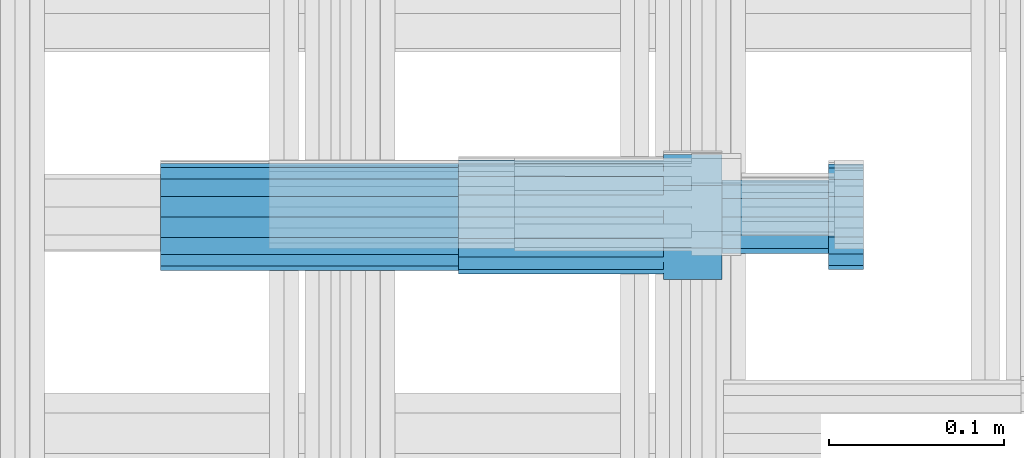
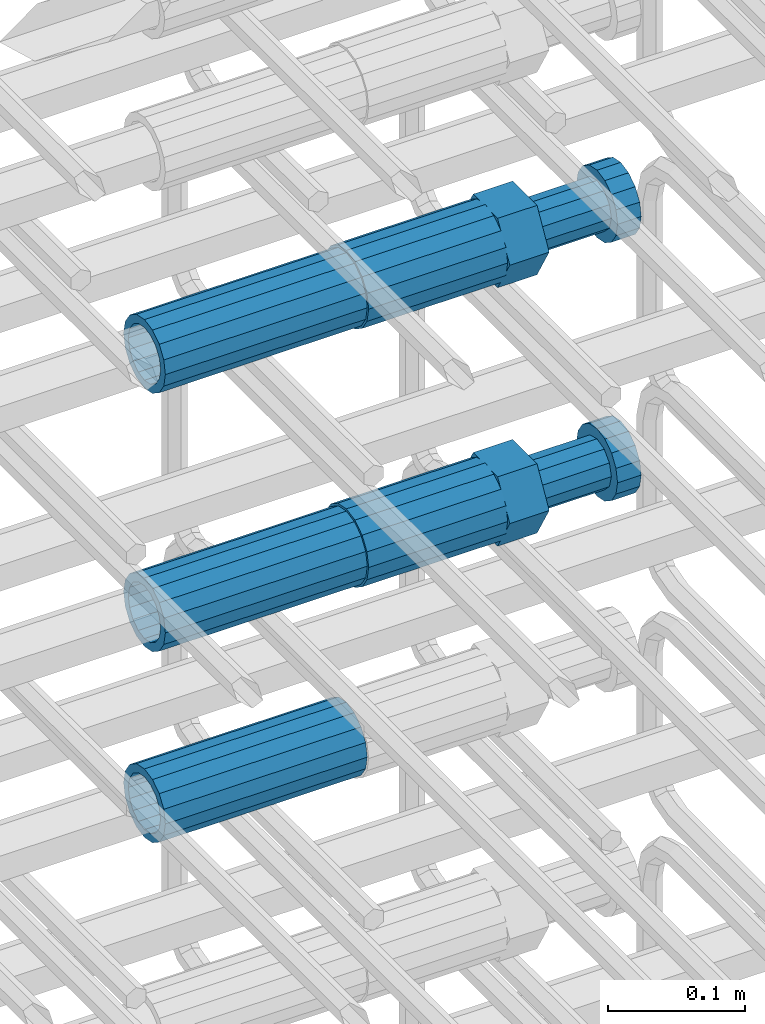
# One storey, part 45 of 177: 5 beams.
"""IFC2X3 building model written with IfcOpenShell, lengths in millimetres."""

import ifcopenshell
import ifcopenshell.guid

model = None  # the IFC model being written
_history = None  # IfcOwnerHistory: only IFC2X3 demands one
_inside = {}  # id of a spatial element -> (the spatial element, [elements in it])
_under = {}  # id of a project, library or spatial element -> (it, [spatial elements below it])
_declared = {}  # id of a project -> (the project, [libraries it declares])
_typed = {}  # id of a type object -> (the type object, [elements of that type])
_made_of = {}  # id of a material, layer set ... -> (it, [elements and type objects made of it])


def new_model(schema):
    """Start an empty IFC model of exactly this schema.

    Asked for "IFC4X3", IfcOpenShell would pick the latest addendum, in which some entities
    have other attributes; the version numbers below select the first issue.
    IFC2X3 requires an IfcOwnerHistory on every rooted entity: one is made here for all.
    """
    global model, _history
    if schema == "IFC4X3":
        model = ifcopenshell.file(schema_version=(4, 3, 0, 0))
    else:
        model = ifcopenshell.file(schema=schema)
    _inside.clear()
    _under.clear()
    _declared.clear()
    _typed.clear()
    _made_of.clear()
    _history = None
    if model.schema == "IFC2X3":
        org = make("IfcOrganization", Name="unknown")
        user = make(
            "IfcPersonAndOrganization",
            ThePerson=make("IfcPerson", FamilyName="unknown"),
            TheOrganization=org,
        )
        app = make(
            "IfcApplication",
            ApplicationDeveloper=org,
            Version="unknown",
            ApplicationFullName="unknown",
            ApplicationIdentifier="unknown",
        )
        _history = make(
            "IfcOwnerHistory",
            OwningUser=user,
            OwningApplication=app,
            ChangeAction="ADDED",
            CreationDate=0,
        )
    return model


def make(cls, **values):
    """One entity of the class cls with the attributes given. An attribute that is None is left unset."""
    return model.create_entity(
        cls, **{name: value for name, value in values.items() if value is not None}
    )


def rooted(cls, **values):
    """An entity with a GlobalId (a new one), such as an element, a storey or a relation."""
    return make(cls, GlobalId=ifcopenshell.guid.new(), OwnerHistory=_history, **values)


def si_unit(unit_type, name, prefix=None):
    """IfcSIUnit, for example si_unit("LENGTHUNIT", "METRE", prefix="MILLI")."""
    return make("IfcSIUnit", UnitType=unit_type, Prefix=prefix, Name=name)


def assignment(units):
    """IfcUnitAssignment: the units of a project."""
    return None if units is None else make("IfcUnitAssignment", Units=units)


def point(xyz):
    """IfcCartesianPoint."""
    return None if xyz is None else make("IfcCartesianPoint", Coordinates=xyz)


def direction(xyz):
    """IfcDirection."""
    return None if xyz is None else make("IfcDirection", DirectionRatios=xyz)


def frame(location, z_axis=None, x_axis=None):
    """IfcAxis2Placement3D, a coordinate frame: its origin and axes. An axis left out is left unset."""
    return make(
        "IfcAxis2Placement3D",
        Location=point(location),
        Axis=direction(z_axis),
        RefDirection=direction(x_axis),
    )


def origin_with_axes():
    """The frame at (0, 0, 0) with the z axis (0, 0, 1) and the x axis (1, 0, 0) written out."""
    return frame((0.0, 0.0, 0.0), z_axis=(0.0, 0.0, 1.0), x_axis=(1.0, 0.0, 0.0))


def place(relative_to, where):
    """IfcLocalPlacement: puts the frame where relative to a parent placement (None: the world)."""
    return make(
        "IfcLocalPlacement", PlacementRelTo=relative_to, RelativePlacement=where
    )


def context(
    kind, dimensions, precision=None, world=None, true_north=None, identifier=None
):
    """IfcGeometricRepresentationContext, for example the 3D "Model" context."""
    return make(
        "IfcGeometricRepresentationContext",
        ContextIdentifier=identifier,
        ContextType=kind,
        CoordinateSpaceDimension=dimensions,
        Precision=precision,
        WorldCoordinateSystem=world,
        TrueNorth=true_north,
    )


def subcontext(parent, identifier, kind, view, scale=None):
    """IfcGeometricRepresentationSubContext, for example "Body" below "Model"."""
    return make(
        "IfcGeometricRepresentationSubContext",
        ContextIdentifier=identifier,
        ContextType=kind,
        ParentContext=parent,
        TargetScale=scale,
        TargetView=view,
    )


def project(units=None, contexts=None):
    """IfcProject with its units and contexts."""
    return rooted(
        "IfcProject",
        Name="project",
        RepresentationContexts=contexts,
        UnitsInContext=assignment(units),
    )


def spatial(cls, under=None, at=None, **own):
    """A site, building, storey or space (cls), placed at a placement, below another one or the project."""
    s = rooted(cls, ObjectPlacement=at, **own)
    if under is not None:
        _under.setdefault(under.id(), (under, []))[1].append(s)
    return s


def faces_of(points, faces, orient=None, outer=None):
    """IfcFace entities. A face is a list of loops; a loop is a list of indices into points, from 0.

    orient and outer hold one flag for each loop. By default every Orientation is true, the
    first loop of a face is its IfcFaceOuterBound and the others are IfcFaceBound.
    """
    made = []
    for i, loops in enumerate(faces):
        bounds = []
        for j, loop in enumerate(loops):
            is_outer = j == 0 if outer is None else outer[i][j]
            bounds.append(
                make(
                    "IfcFaceOuterBound" if is_outer else "IfcFaceBound",
                    Bound=make("IfcPolyLoop", Polygon=[points[k] for k in loop]),
                    Orientation=True if orient is None else orient[i][j],
                )
            )
        made.append(make("IfcFace", Bounds=bounds))
    return made


def faceted_brep(points, faces, orient=None, outer=None, voids=None):
    """IfcFacetedBrep: a solid bounded by flat faces; with voids (closed shells), ...WithVoids."""
    shared = [point(p) for p in points]
    hull = make("IfcClosedShell", CfsFaces=faces_of(shared, faces, orient, outer))
    if voids is None:
        return make("IfcFacetedBrep", Outer=hull)
    return make(
        "IfcFacetedBrepWithVoids",
        Outer=hull,
        Voids=[
            make(cls, CfsFaces=faces_of(shared, fs, o, b)) for cls, fs, o, b in voids
        ],
    )


def shape(context_of_items, identifier, shape_type, items):
    """IfcShapeRepresentation: the items that make up one representation, for example the "Body"."""
    return make(
        "IfcShapeRepresentation",
        ContextOfItems=context_of_items,
        RepresentationIdentifier=identifier,
        RepresentationType=shape_type,
        Items=items,
    )


def material(Name=None, Category=None):
    """IfcMaterial."""
    return make("IfcMaterial", Name=Name, Category=Category)


def made_of(thing, what):
    """Note that an element or type object is made of a material, layer set ...; save() writes the relation."""
    if what is not None:
        _made_of.setdefault(what.id(), (what, []))[1].append(thing)
    return thing


def type_object(cls, material=None, **own):
    """A type object (cls), such as IfcWallType, which elements share."""
    return made_of(rooted(cls, **own), material)


def element(
    cls,
    number,
    at=None,
    inside=None,
    cuts=None,
    type_object=None,
    material=None,
    context=None,
    identifier="Body",
    shape_type=None,
    held_by="IfcProductDefinitionShape",
    body=None,
    shapes=None,
    **own,
):
    """One element of the class cls, such as IfcWall. Its Tag is "e" and its number.

    at: its placement. inside: the storey or other place that contains it. cuts: it is an
    opening in that element (IfcRelVoidsElement). A single representation is given by context,
    identifier, shape_type and body (its items); several are given by shapes. held_by: the class
    of the entity that holds the representations. save() writes the other relations.
    """
    e = rooted(cls, Tag="e%d" % number, ObjectPlacement=at, **own)
    if body is not None:
        shapes = [shape(context, identifier, shape_type, body)]
    if shapes is not None:
        e.Representation = make(held_by, Representations=shapes)
    if inside is not None:
        _inside.setdefault(inside.id(), (inside, []))[1].append(e)
    if cuts is not None:
        rooted(
            "IfcRelVoidsElement", RelatingBuildingElement=cuts, RelatedOpeningElement=e
        )
    if type_object is not None:
        _typed.setdefault(type_object.id(), (type_object, []))[1].append(e)
    return made_of(e, material)


def aggregate(whole, parts):
    """IfcRelAggregates: a whole, such as a stair, and the parts it consists of."""
    return rooted("IfcRelAggregates", RelatingObject=whole, RelatedObjects=parts)


def save(model, path):
    """Write the relations noted so far, then the file.

    IfcRelAggregates (storeys below a building ...), IfcRelContainedInSpatialStructure (elements
    in a storey), IfcRelDefinesByType, IfcRelAssociatesMaterial and IfcRelDeclares: one each for
    every whole, place, type object, material and project.
    """
    for whole, parts in _under.values():
        aggregate(whole, parts)
    for where, things in _inside.values():
        rooted(
            "IfcRelContainedInSpatialStructure",
            RelatedElements=things,
            RelatingStructure=where,
        )
    for kind, things in _typed.values():
        rooted("IfcRelDefinesByType", RelatedObjects=things, RelatingType=kind)
    for what, things in _made_of.values():
        rooted("IfcRelAssociatesMaterial", RelatedObjects=things, RelatingMaterial=what)
    for by, libraries in _declared.values():
        rooted("IfcRelDeclares", RelatingContext=by, RelatedDefinitions=libraries)
    model.write(path)


model = new_model("IFC2X3")

# Units and contexts
model_context_1 = context("Model", 3, precision=1e-05, world=origin_with_axes())
model_context_2 = context("Model", 3, precision=1e-05, world=origin_with_axes())
body_context = subcontext(model_context_2, "Body", "Model", "MODEL_VIEW")
ifc_project = project(units=[si_unit("LENGTHUNIT", "METRE", prefix="MILLI"), si_unit("AREAUNIT", "SQUARE_METRE"), si_unit("VOLUMEUNIT", "CUBIC_METRE"), si_unit("MASSUNIT", "GRAM", prefix="KILO"), si_unit("TIMEUNIT", "SECOND"), si_unit("PLANEANGLEUNIT", "RADIAN"), si_unit("SOLIDANGLEUNIT", "STERADIAN"), si_unit("THERMODYNAMICTEMPERATUREUNIT", "DEGREE_CELSIUS"), si_unit("LUMINOUSINTENSITYUNIT", "LUMEN")], contexts=[model_context_1])

# Site, building, storey
site_placement = place(None, origin_with_axes())
site = spatial("IfcSite", under=ifc_project, at=site_placement, CompositionType="ELEMENT")
building_placement = place(site_placement, origin_with_axes())
building = spatial("IfcBuilding", under=site, at=building_placement, Name="Undefined", CompositionType="ELEMENT")
storey_placement = place(building_placement, origin_with_axes())
storey = spatial("IfcBuildingStorey", under=building, at=storey_placement, Name="Undefined", CompositionType="ELEMENT", Elevation=0.0)

# Beams
ifc_material = material(Name="STEEL/S275")
beam_type_1 = type_object("IfcBeamType", PredefinedType="NOTDEFINED")
beam_1_placement = place(storey_placement, frame((2030819.00847313, 6206282.98588032, 22039.9868004323), z_axis=(0.0, 0.0, -1.0), x_axis=(1.0, 0.0, 0.0)))
element("IfcBeam", 1, at=beam_1_placement, inside=storey, type_object=beam_type_1, material=ifc_material, Name="AG40N", context=body_context, shape_type="Brep", body=[
    faceted_brep([(0.0, -23.5000000001164, -9.31322574615479e-10), (0.0, -21.7111690140155, 8.99306066054851), (170.0, -21.7111690140155, 8.99306066054851), (170.0, -23.5, 0.0), (0.0, -16.6170093578839, 16.6170093575493), (170.0, -16.6170093578839, 16.6170093575493), (0.0, -8.99306066057943, 21.7111690137535), (170.0, -8.99306066057943, 21.7111690137535), (0.0, 1.16415321826935e-10, 23.5), (170.0, 0.0, 23.5), (0.0, 8.99306066057943, 21.7111690137535), (170.0, 8.99306066057943, 21.7111690137535), (0.0, 16.6170093578839, 16.6170093575493), (170.0, 16.6170093578839, 16.6170093575493), (0.0, 21.7111690140155, 8.99306066054851), (170.0, 21.7111690140155, 8.99306066054851), (0.0, 23.5000000001164, -9.31322574615479e-10), (170.0, 23.5, 0.0), (0.0, 21.7111690140155, -8.99306066054851), (170.0, 21.7111690140155, -8.99306066054851), (0.0, 16.6170093578839, -16.6170093575493), (170.0, 16.6170093578839, -16.6170093575493), (0.0, 8.99306066057943, -21.7111690137535), (170.0, 8.99306066057943, -21.7111690137535), (0.0, 1.16415321826935e-10, -23.5000000009313), (170.0, 0.0, -23.5), (0.0, -8.99306066057943, -21.7111690137535), (170.0, -8.99306066057943, -21.7111690137535), (0.0, -16.6170093578839, -16.6170093575493), (170.0, -16.6170093578839, -16.6170093575493), (0.0, -21.7111690140155, -8.99306066054851), (170.0, -21.7111690140155, -8.99306066054851), (0.0, -30.5, 0.0), (0.0, -28.1783257415937, -11.6718446873128), (170.0, -28.1783257415937, -11.6718446873128), (170.0, -30.5, 0.0), (0.0, -21.5667568261888, -21.5667568258941), (170.0, -21.5667568261888, -21.5667568258941), (0.0, -11.6718446871346, -28.1783257415518), (170.0, -11.6718446871346, -28.1783257415518), (0.0, 0.0, -30.5), (170.0, 0.0, -30.5), (0.0, 11.6718446871346, -28.1783257415518), (170.0, 11.6718446871346, -28.1783257415518), (0.0, 21.5667568261888, -21.5667568258941), (170.0, 21.5667568261888, -21.5667568258941), (0.0, 28.1783257415937, -11.6718446873128), (170.0, 28.1783257415937, -11.6718446873128), (0.0, 30.5, 0.0), (170.0, 30.5, 0.0), (0.0, 28.1783257415937, 11.6718446873128), (170.0, 28.1783257415937, 11.6718446873128), (0.0, 21.5667568261888, 21.5667568258941), (170.0, 21.5667568261888, 21.5667568258941), (0.0, 11.6718446871346, 28.1783257415518), (170.0, 11.6718446871346, 28.1783257415518), (0.0, 0.0, 30.5), (170.0, 0.0, 30.5), (0.0, -11.6718446871346, 28.1783257415518), (170.0, -11.6718446871346, 28.1783257415518), (0.0, -21.5667568261888, 21.5667568258941), (170.0, -21.5667568261888, 21.5667568258941), (0.0, -28.1783257415937, 11.6718446873128), (170.0, -28.1783257415937, 11.6718446873128)], [[[0, 1, 2, 3]], [[1, 4, 5, 2]], [[4, 6, 7, 5]], [[6, 8, 9, 7]], [[8, 10, 11, 9]], [[10, 12, 13, 11]], [[12, 14, 15, 13]], [[14, 16, 17, 15]], [[16, 18, 19, 17]], [[18, 20, 21, 19]], [[20, 22, 23, 21]], [[22, 24, 25, 23]], [[24, 26, 27, 25]], [[26, 28, 29, 27]], [[28, 30, 31, 29]], [[30, 0, 3, 31]], [[32, 33, 34, 35]], [[33, 36, 37, 34]], [[36, 38, 39, 37]], [[38, 40, 41, 39]], [[40, 42, 43, 41]], [[42, 44, 45, 43]], [[44, 46, 47, 45]], [[46, 48, 49, 47]], [[48, 50, 51, 49]], [[50, 52, 53, 51]], [[52, 54, 55, 53]], [[54, 56, 57, 55]], [[56, 58, 59, 57]], [[58, 60, 61, 59]], [[60, 62, 63, 61]], [[62, 32, 35, 63]], [[37, 39, 41, 43, 45, 47, 49, 51, 53, 55, 57, 59, 61, 63, 35, 34], [5, 7, 9, 11, 13, 15, 17, 19, 21, 23, 25, 27, 29, 31, 3, 2]], [[62, 60, 58, 56, 54, 52, 50, 48, 46, 44, 42, 40, 38, 36, 33, 32], [30, 28, 26, 24, 22, 20, 18, 16, 14, 12, 10, 8, 6, 4, 1, 0]]]),
])
beam_2_placement = place(storey_placement, frame((2030819.00847313, 6206282.98588032, 21809.9868004332), z_axis=(0.0, 0.0, -1.0), x_axis=(1.0, 0.0, 0.0)))
element("IfcBeam", 2, at=beam_2_placement, inside=storey, type_object=beam_type_1, material=ifc_material, Name="AG40N", context=body_context, shape_type="Brep", body=[
    faceted_brep([(0.0, -23.5000000001164, -9.31322574615479e-10), (0.0, -21.7111690140155, 8.99306066054851), (170.0, -21.7111690140155, 8.99306066054851), (170.0, -23.5, 0.0), (0.0, -16.6170093578839, 16.6170093575493), (170.0, -16.6170093578839, 16.6170093575493), (0.0, -8.99306066057943, 21.7111690137535), (170.0, -8.99306066057943, 21.7111690137535), (0.0, 1.16415321826935e-10, 23.5), (170.0, 0.0, 23.5), (0.0, 8.99306066057943, 21.7111690137535), (170.0, 8.99306066057943, 21.7111690137535), (0.0, 16.6170093578839, 16.6170093575493), (170.0, 16.6170093578839, 16.6170093575493), (0.0, 21.7111690140155, 8.99306066054851), (170.0, 21.7111690140155, 8.99306066054851), (0.0, 23.5000000001164, -9.31322574615479e-10), (170.0, 23.5, 0.0), (0.0, 21.7111690140155, -8.99306066054851), (170.0, 21.7111690140155, -8.99306066054851), (0.0, 16.6170093578839, -16.6170093575493), (170.0, 16.6170093578839, -16.6170093575493), (0.0, 8.99306066057943, -21.7111690137535), (170.0, 8.99306066057943, -21.7111690137535), (0.0, 1.16415321826935e-10, -23.5000000009313), (170.0, 0.0, -23.5), (0.0, -8.99306066057943, -21.7111690137535), (170.0, -8.99306066057943, -21.7111690137535), (0.0, -16.6170093578839, -16.6170093575493), (170.0, -16.6170093578839, -16.6170093575493), (0.0, -21.7111690140155, -8.99306066054851), (170.0, -21.7111690140155, -8.99306066054851), (0.0, -30.5, 0.0), (0.0, -28.1783257415937, -11.6718446873128), (170.0, -28.1783257415937, -11.6718446873128), (170.0, -30.5, 0.0), (0.0, -21.5667568261888, -21.5667568258941), (170.0, -21.5667568261888, -21.5667568258941), (0.0, -11.6718446871346, -28.1783257415518), (170.0, -11.6718446871346, -28.1783257415518), (0.0, 0.0, -30.5), (170.0, 0.0, -30.5), (0.0, 11.6718446871346, -28.1783257415518), (170.0, 11.6718446871346, -28.1783257415518), (0.0, 21.5667568261888, -21.5667568258941), (170.0, 21.5667568261888, -21.5667568258941), (0.0, 28.1783257415937, -11.6718446873128), (170.0, 28.1783257415937, -11.6718446873128), (0.0, 30.5, 0.0), (170.0, 30.5, 0.0), (0.0, 28.1783257415937, 11.6718446873128), (170.0, 28.1783257415937, 11.6718446873128), (0.0, 21.5667568261888, 21.5667568258941), (170.0, 21.5667568261888, 21.5667568258941), (0.0, 11.6718446871346, 28.1783257415518), (170.0, 11.6718446871346, 28.1783257415518), (0.0, 0.0, 30.5), (170.0, 0.0, 30.5), (0.0, -11.6718446871346, 28.1783257415518), (170.0, -11.6718446871346, 28.1783257415518), (0.0, -21.5667568261888, 21.5667568258941), (170.0, -21.5667568261888, 21.5667568258941), (0.0, -28.1783257415937, 11.6718446873128), (170.0, -28.1783257415937, 11.6718446873128)], [[[0, 1, 2, 3]], [[1, 4, 5, 2]], [[4, 6, 7, 5]], [[6, 8, 9, 7]], [[8, 10, 11, 9]], [[10, 12, 13, 11]], [[12, 14, 15, 13]], [[14, 16, 17, 15]], [[16, 18, 19, 17]], [[18, 20, 21, 19]], [[20, 22, 23, 21]], [[22, 24, 25, 23]], [[24, 26, 27, 25]], [[26, 28, 29, 27]], [[28, 30, 31, 29]], [[30, 0, 3, 31]], [[32, 33, 34, 35]], [[33, 36, 37, 34]], [[36, 38, 39, 37]], [[38, 40, 41, 39]], [[40, 42, 43, 41]], [[42, 44, 45, 43]], [[44, 46, 47, 45]], [[46, 48, 49, 47]], [[48, 50, 51, 49]], [[50, 52, 53, 51]], [[52, 54, 55, 53]], [[54, 56, 57, 55]], [[56, 58, 59, 57]], [[58, 60, 61, 59]], [[60, 62, 63, 61]], [[62, 32, 35, 63]], [[37, 39, 41, 43, 45, 47, 49, 51, 53, 55, 57, 59, 61, 63, 35, 34], [5, 7, 9, 11, 13, 15, 17, 19, 21, 23, 25, 27, 29, 31, 3, 2]], [[62, 60, 58, 56, 54, 52, 50, 48, 46, 44, 42, 40, 38, 36, 33, 32], [30, 28, 26, 24, 22, 20, 18, 16, 14, 12, 10, 8, 6, 4, 1, 0]]]),
])
beam_3_placement = place(storey_placement, frame((2030819.00847313, 6206282.98588032, 21639.9868004324), z_axis=(0.0, 0.0, -1.0), x_axis=(1.0, 0.0, 0.0)))
element("IfcBeam", 3, at=beam_3_placement, inside=storey, type_object=beam_type_1, material=ifc_material, Name="AG40N", context=body_context, shape_type="Brep", body=[
    faceted_brep([(0.0, -23.5000000001164, -9.31322574615479e-10), (0.0, -21.7111690140155, 8.99306066054851), (170.0, -21.7111690140155, 8.99306066054851), (170.0, -23.5, 0.0), (0.0, -16.6170093578839, 16.6170093575493), (170.0, -16.6170093578839, 16.6170093575493), (0.0, -8.99306066057943, 21.7111690137535), (170.0, -8.99306066057943, 21.7111690137535), (0.0, 1.16415321826935e-10, 23.5), (170.0, 0.0, 23.5), (0.0, 8.99306066057943, 21.7111690137535), (170.0, 8.99306066057943, 21.7111690137535), (0.0, 16.6170093578839, 16.6170093575493), (170.0, 16.6170093578839, 16.6170093575493), (0.0, 21.7111690140155, 8.99306066054851), (170.0, 21.7111690140155, 8.99306066054851), (0.0, 23.5000000001164, -9.31322574615479e-10), (170.0, 23.5, 0.0), (0.0, 21.7111690140155, -8.99306066054851), (170.0, 21.7111690140155, -8.99306066054851), (0.0, 16.6170093578839, -16.6170093575493), (170.0, 16.6170093578839, -16.6170093575493), (0.0, 8.99306066057943, -21.7111690137535), (170.0, 8.99306066057943, -21.7111690137535), (0.0, 1.16415321826935e-10, -23.5000000009313), (170.0, 0.0, -23.5), (0.0, -8.99306066057943, -21.7111690137535), (170.0, -8.99306066057943, -21.7111690137535), (0.0, -16.6170093578839, -16.6170093575493), (170.0, -16.6170093578839, -16.6170093575493), (0.0, -21.7111690140155, -8.99306066054851), (170.0, -21.7111690140155, -8.99306066054851), (0.0, -30.5, 0.0), (0.0, -28.1783257415937, -11.6718446873128), (170.0, -28.1783257415937, -11.6718446873128), (170.0, -30.5, 0.0), (0.0, -21.5667568261888, -21.5667568258941), (170.0, -21.5667568261888, -21.5667568258941), (0.0, -11.6718446871346, -28.1783257415518), (170.0, -11.6718446871346, -28.1783257415518), (0.0, 0.0, -30.5), (170.0, 0.0, -30.5), (0.0, 11.6718446871346, -28.1783257415518), (170.0, 11.6718446871346, -28.1783257415518), (0.0, 21.5667568261888, -21.5667568258941), (170.0, 21.5667568261888, -21.5667568258941), (0.0, 28.1783257415937, -11.6718446873128), (170.0, 28.1783257415937, -11.6718446873128), (0.0, 30.5, 0.0), (170.0, 30.5, 0.0), (0.0, 28.1783257415937, 11.6718446873128), (170.0, 28.1783257415937, 11.6718446873128), (0.0, 21.5667568261888, 21.5667568258941), (170.0, 21.5667568261888, 21.5667568258941), (0.0, 11.6718446871346, 28.1783257415518), (170.0, 11.6718446871346, 28.1783257415518), (0.0, 0.0, 30.5), (170.0, 0.0, 30.5), (0.0, -11.6718446871346, 28.1783257415518), (170.0, -11.6718446871346, 28.1783257415518), (0.0, -21.5667568261888, 21.5667568258941), (170.0, -21.5667568261888, 21.5667568258941), (0.0, -28.1783257415937, 11.6718446873128), (170.0, -28.1783257415937, 11.6718446873128)], [[[0, 1, 2, 3]], [[1, 4, 5, 2]], [[4, 6, 7, 5]], [[6, 8, 9, 7]], [[8, 10, 11, 9]], [[10, 12, 13, 11]], [[12, 14, 15, 13]], [[14, 16, 17, 15]], [[16, 18, 19, 17]], [[18, 20, 21, 19]], [[20, 22, 23, 21]], [[22, 24, 25, 23]], [[24, 26, 27, 25]], [[26, 28, 29, 27]], [[28, 30, 31, 29]], [[30, 0, 3, 31]], [[32, 33, 34, 35]], [[33, 36, 37, 34]], [[36, 38, 39, 37]], [[38, 40, 41, 39]], [[40, 42, 43, 41]], [[42, 44, 45, 43]], [[44, 46, 47, 45]], [[46, 48, 49, 47]], [[48, 50, 51, 49]], [[50, 52, 53, 51]], [[52, 54, 55, 53]], [[54, 56, 57, 55]], [[56, 58, 59, 57]], [[58, 60, 61, 59]], [[60, 62, 63, 61]], [[62, 32, 35, 63]], [[37, 39, 41, 43, 45, 47, 49, 51, 53, 55, 57, 59, 61, 63, 35, 34], [5, 7, 9, 11, 13, 15, 17, 19, 21, 23, 25, 27, 29, 31, 3, 2]], [[62, 60, 58, 56, 54, 52, 50, 48, 46, 44, 42, 40, 38, 36, 33, 32], [30, 28, 26, 24, 22, 20, 18, 16, 14, 12, 10, 8, 6, 4, 1, 0]]]),
])
beam_type_2 = type_object("IfcBeamType", Name="ROD65", PredefinedType="NOTDEFINED")
beam_4_placement = place(storey_placement, frame((2030989.00847313, 6206282.98588032, 22039.9868004323), z_axis=(0.0, 0.0, -1.0), x_axis=(1.0, 0.0, 0.0)))
element("IfcBeam", 4, at=beam_4_placement, inside=storey, type_object=beam_type_2, material=ifc_material, Name="AGB40", ObjectType="ROD65", context=body_context, shape_type="Brep", body=[
    faceted_brep([(117.0, 8.17543110251427, 30.873805644922), (117.0, 17.8250000001863, 30.873805644922), (117.0, 22.0056958701462, 23.6326279877685), (117.0, 12.4372115517035, 30.0260848065373), (117.0, -17.8250000001863, 30.873805644922), (150.200000000186, -17.8250000001863, 30.873805644922), (150.200000000186, 17.8250000001863, 30.873805644922), (117.0, -8.17543110251427, 30.873805644922), (117.0, -12.4372115517035, 30.0260848065373), (117.0, -22.0056958701462, 23.6326279877685), (117.0, -35.6500000003725, 0.0), (150.200000000186, -35.6500000003725, 0.0), (117.0, -30.8443150008097, 8.32369058486074), (117.0, -32.5, 0.0), (117.0, -30.8443150008097, -8.32369058462791), (117.0, -17.8250000001863, -30.873805644922), (150.200000000186, -17.8250000001863, -30.873805644922), (117.0, -22.0056958701462, -23.6326279877685), (117.0, -12.4372115517035, -30.0260848065373), (117.0, -8.17543110251427, -30.873805644922), (117.0, 17.8250000001863, -30.873805644922), (150.200000000186, 17.8250000001863, -30.873805644922), (117.0, 8.17543110251427, -30.873805644922), (117.0, 22.0056958701462, -23.6326279877685), (117.0, 12.4372115517035, -30.0260848065373), (117.0, 35.6500000003725, 0.0), (150.200000000186, 35.6500000003725, 0.0), (117.0, 30.8443150008097, -8.32369058486074), (117.0, 30.8443150008097, 8.32369058462791), (117.0, 32.5, 0.0), (0.0, -22.9809703892097, 22.9809703885621), (0.0, -30.0260848058388, 12.4372115518636), (117.0, -30.0260848067701, 12.4372115519363), (117.0, -22.9809703882784, 22.9809703885112), (-2.3283064365387e-10, 22.9809703892097, -22.9809703885639), (-4.65661287307739e-10, 30.0260848077014, -12.4372115518672), (117.0, 30.0260848067701, -12.4372115519363), (117.0, 22.9809703882784, -22.9809703885112), (-2.3283064365387e-10, -30.0260848067701, -12.4372115518672), (-2.3283064365387e-10, -22.9809703892097, -22.9809703885621), (117.0, -22.9809703882784, -22.9809703885112), (117.0, -30.0260848067701, -12.4372115519363), (-2.3283064365387e-10, -12.4372115507722, 30.0260848066137), (-2.3283064365387e-10, 9.31322574615479e-10, 32.4999999999982), (-2.3283064365387e-10, 12.4372115526348, 30.0260848066137), (0.0, 22.9809703892097, 22.9809703885621), (-2.3283064365387e-10, 30.0260848077014, 12.4372115518636), (-2.3283064365387e-10, 32.5, 0.0), (-2.3283064365387e-10, 12.4372115526348, -30.0260848066173), (-2.3283064365387e-10, 9.31322574615479e-10, -32.5), (-2.3283064365387e-10, -12.4372115517035, -30.0260848066173), (-4.65661287307739e-10, -32.4999999990687, -1.81898940354586e-12), (117.0, 22.9809703882784, 22.9809703885112), (117.0, 30.0260848067701, 12.4372115519363), (117.0, 0.0, -32.5), (117.0, 0.0, 32.5), (150.200000000186, 10.5, -18.1865334794857), (150.200000000186, 0.0, -21.0), (150.200000000186, -10.5, -18.1865334794857), (150.200000000186, -18.18653347902, -10.5), (150.200000000186, -21.0, 0.0), (150.200000000186, -18.18653347902, 10.5), (150.200000000186, -10.5, 18.1865334794857), (150.200000000186, 0.0, 21.0), (150.200000000186, 10.5, 18.1865334794857), (150.200000000186, 18.18653347902, 10.5), (150.200000000186, 21.0, 0.0), (150.200000000186, 18.18653347902, -10.5), (210.980000000447, -18.18653347902, 10.5), (210.980000000447, -21.0, 0.0), (210.980000000447, -10.5, 18.1865334794857), (210.980000000447, 0.0, 21.0), (210.980000000447, 10.5, 18.1865334794857), (210.980000000447, 18.18653347902, 10.5), (210.980000000447, 21.0, 0.0), (210.980000000447, 18.18653347902, -10.5), (210.980000000447, 10.5, -18.1865334794857), (210.980000000447, 0.0, -21.0), (210.980000000447, -10.5, -18.1865334794857), (210.980000000447, -18.18653347902, -10.5), (211.001368442696, -27.7269937992096, -11.491116326768), (211.003082550167, -21.2238094303757, -21.223815418547), (231.002518367059, -21.2131944671273, -21.2132004550658), (231.000804259587, -27.7163788359612, -11.4805013632867), (211.001368440451, -11.4911085031927, -27.7269970395137), (231.000804257343, -11.4804935399443, -27.7163820760325), (210.996487071217, -0.0106065049767494, -30.0106107392348), (230.995922888109, 8.45827162265778e-06, -29.9999957757536), (210.989181586672, 11.46989420522, -27.7269970329944), (230.988617403564, 11.4805091684684, -27.7163820695132), (210.980564180623, 21.2025914648548, -21.2238154064398), (230.979999997515, 21.2132064281031, -21.2132004429586), (210.971946775022, 27.7057703435421, -11.4911163107026), (230.971382591913, 27.7163853067905, -11.4805013472214), (210.96464129175, 29.9893808094785, -0.0106149562634528), (230.964077108642, 29.9999957727268, 7.21774995326996e-09), (210.959759924415, 27.7057638689876, 11.4698863970116), (230.959195741307, 27.7163788322359, 11.4805013604928), (210.958045816944, 21.2025795001537, 21.2025854887906), (230.957481633835, 21.213194463402, 21.2132004522718), (210.95975992666, 11.4698785729706, 27.7057671097573), (230.959195743551, 11.480493536219, 27.7163820732385), (210.964641295894, -0.010623425245285, 29.9893808094785), (230.964077112785, -8.46199691295624e-06, 29.9999957729597), (210.971946780439, -11.4911241354421, 27.705767103238), (230.97138259733, -11.4805091721937, 27.7163820667192), (210.980564186488, -21.2238213950768, 21.2025854766835), (230.980000003379, -21.2132064318284, 21.2132004401647), (210.989181592089, -27.7270002737641, 11.4698863809463), (230.988617408981, -27.7163853105158, 11.4805013444275), (210.996487075361, -30.0106107397005, -0.0106149734929204), (230.995922892253, -29.9999957764521, -1.00117176771164e-08)], [[[0, 1, 2, 3]], [[4, 5, 6, 1, 0, 7]], [[4, 7, 8, 9]], [[10, 11, 5, 4, 9, 12]], [[10, 12, 13, 14]], [[15, 16, 11, 10, 14, 17]], [[15, 17, 18, 19]], [[20, 21, 16, 15, 19, 22]], [[23, 20, 22, 24]], [[25, 26, 21, 20, 23, 27]], [[28, 25, 27, 29]], [[30, 31, 32, 33]], [[34, 35, 36, 37]], [[38, 39, 40, 41]], [[31, 30, 42, 43, 44, 45, 46, 47, 35, 34, 48, 49, 50, 39, 38, 51]], [[46, 45, 52, 53]], [[29, 47, 46, 53, 28]], [[27, 36, 35, 47, 29]], [[23, 37, 36, 27]], [[24, 48, 34, 37, 23]], [[22, 54, 49, 48, 24]], [[19, 54, 22]], [[18, 50, 49, 54, 19]], [[17, 40, 39, 50, 18]], [[14, 41, 40, 17]], [[13, 51, 38, 41, 14]], [[12, 32, 31, 51, 13]], [[9, 33, 32, 12]], [[8, 42, 30, 33, 9]], [[7, 55, 43, 42, 8]], [[0, 55, 7]], [[3, 44, 43, 55, 0]], [[2, 52, 45, 44, 3]], [[28, 53, 52, 2]], [[1, 6, 26, 25, 28, 2]], [[5, 11, 16, 21, 26, 6], [56, 57, 58, 59, 60, 61, 62, 63, 64, 65, 66, 67]], [[68, 61, 60, 69]], [[70, 62, 61, 68]], [[71, 63, 62, 70]], [[72, 64, 63, 71]], [[73, 65, 64, 72]], [[74, 66, 65, 73]], [[75, 67, 66, 74]], [[76, 56, 67, 75]], [[77, 57, 56, 76]], [[78, 58, 57, 77]], [[79, 59, 58, 78]], [[69, 60, 59, 79]], [[80, 81, 82, 83]], [[81, 84, 85, 82]], [[84, 86, 87, 85]], [[86, 88, 89, 87]], [[88, 90, 91, 89]], [[90, 92, 93, 91]], [[92, 94, 95, 93]], [[94, 96, 97, 95]], [[96, 98, 99, 97]], [[98, 100, 101, 99]], [[100, 102, 103, 101]], [[102, 104, 105, 103]], [[104, 106, 107, 105]], [[106, 108, 109, 107]], [[108, 110, 111, 109]], [[82, 85, 87, 89, 91, 93, 95, 97, 99, 101, 103, 105, 107, 109, 111, 83]], [[110, 80, 83, 111]], [[108, 106, 104, 102, 100, 98, 96, 94, 92, 90, 88, 86, 84, 81, 80, 110], [75, 74, 73, 72, 71, 70, 68, 69, 79, 78, 77, 76]]]),
])
beam_5_placement = place(storey_placement, frame((2030989.00847313, 6206282.98588032, 21809.9868004332), z_axis=(0.0, 0.0, -1.0), x_axis=(1.0, 0.0, 0.0)))
element("IfcBeam", 5, at=beam_5_placement, inside=storey, type_object=beam_type_2, material=ifc_material, Name="AGB40", ObjectType="ROD65", context=body_context, shape_type="Brep", body=[
    faceted_brep([(117.0, 8.17543110251427, 30.873805644922), (117.0, 17.8250000001863, 30.873805644922), (117.0, 22.0056958701462, 23.6326279877685), (117.0, 12.4372115517035, 30.0260848065373), (117.0, -17.8250000001863, 30.873805644922), (150.200000000186, -17.8250000001863, 30.873805644922), (150.200000000186, 17.8250000001863, 30.873805644922), (117.0, -8.17543110251427, 30.873805644922), (117.0, -12.4372115517035, 30.0260848065373), (117.0, -22.0056958701462, 23.6326279877685), (117.0, -35.6500000003725, 0.0), (150.200000000186, -35.6500000003725, 0.0), (117.0, -30.8443150008097, 8.32369058486074), (117.0, -32.5, 0.0), (117.0, -30.8443150008097, -8.32369058462791), (117.0, -17.8250000001863, -30.873805644922), (150.200000000186, -17.8250000001863, -30.873805644922), (117.0, -22.0056958701462, -23.6326279877685), (117.0, -12.4372115517035, -30.0260848065373), (117.0, -8.17543110251427, -30.873805644922), (117.0, 17.8250000001863, -30.873805644922), (150.200000000186, 17.8250000001863, -30.873805644922), (117.0, 8.17543110251427, -30.873805644922), (117.0, 22.0056958701462, -23.6326279877685), (117.0, 12.4372115517035, -30.0260848065373), (117.0, 35.6500000003725, 0.0), (150.200000000186, 35.6500000003725, 0.0), (117.0, 30.8443150008097, -8.32369058486074), (117.0, 30.8443150008097, 8.32369058462791), (117.0, 32.5, 0.0), (0.0, -22.9809703892097, 22.9809703885621), (0.0, -30.0260848058388, 12.4372115518636), (117.0, -30.0260848067701, 12.4372115519363), (117.0, -22.9809703882784, 22.9809703885112), (-2.3283064365387e-10, 22.9809703892097, -22.9809703885639), (-4.65661287307739e-10, 30.0260848077014, -12.4372115518672), (117.0, 30.0260848067701, -12.4372115519363), (117.0, 22.9809703882784, -22.9809703885112), (-2.3283064365387e-10, -30.0260848067701, -12.4372115518672), (-2.3283064365387e-10, -22.9809703892097, -22.9809703885621), (117.0, -22.9809703882784, -22.9809703885112), (117.0, -30.0260848067701, -12.4372115519363), (-2.3283064365387e-10, -12.4372115507722, 30.0260848066137), (-2.3283064365387e-10, 9.31322574615479e-10, 32.4999999999982), (-2.3283064365387e-10, 12.4372115526348, 30.0260848066137), (0.0, 22.9809703892097, 22.9809703885621), (-2.3283064365387e-10, 30.0260848077014, 12.4372115518636), (-2.3283064365387e-10, 32.5, 0.0), (-2.3283064365387e-10, 12.4372115526348, -30.0260848066173), (-2.3283064365387e-10, 9.31322574615479e-10, -32.5), (-2.3283064365387e-10, -12.4372115517035, -30.0260848066173), (-4.65661287307739e-10, -32.4999999990687, -1.81898940354586e-12), (117.0, 22.9809703882784, 22.9809703885112), (117.0, 30.0260848067701, 12.4372115519363), (117.0, 0.0, -32.5), (117.0, 0.0, 32.5), (150.200000000186, 10.5, -18.1865334794857), (150.200000000186, 0.0, -21.0), (150.200000000186, -10.5, -18.1865334794857), (150.200000000186, -18.18653347902, -10.5), (150.200000000186, -21.0, 0.0), (150.200000000186, -18.18653347902, 10.5), (150.200000000186, -10.5, 18.1865334794857), (150.200000000186, 0.0, 21.0), (150.200000000186, 10.5, 18.1865334794857), (150.200000000186, 18.18653347902, 10.5), (150.200000000186, 21.0, 0.0), (150.200000000186, 18.18653347902, -10.5), (210.980000000447, -18.18653347902, 10.5), (210.980000000447, -21.0, 0.0), (210.980000000447, -10.5, 18.1865334794857), (210.980000000447, 0.0, 21.0), (210.980000000447, 10.5, 18.1865334794857), (210.980000000447, 18.18653347902, 10.5), (210.980000000447, 21.0, 0.0), (210.980000000447, 18.18653347902, -10.5), (210.980000000447, 10.5, -18.1865334794857), (210.980000000447, 0.0, -21.0), (210.980000000447, -10.5, -18.1865334794857), (210.980000000447, -18.18653347902, -10.5), (211.001368442696, -27.7269937992096, -11.491116326768), (211.003082550167, -21.2238094303757, -21.223815418547), (231.002518367059, -21.2131944671273, -21.2132004550658), (231.000804259587, -27.7163788359612, -11.4805013632867), (211.001368440451, -11.4911085031927, -27.7269970395137), (231.000804257343, -11.4804935399443, -27.7163820760325), (210.996487071217, -0.0106065049767494, -30.0106107392348), (230.995922888109, 8.45827162265778e-06, -29.9999957757536), (210.989181586672, 11.46989420522, -27.7269970329944), (230.988617403564, 11.4805091684684, -27.7163820695132), (210.980564180623, 21.2025914648548, -21.2238154064398), (230.979999997515, 21.2132064281031, -21.2132004429586), (210.971946775022, 27.7057703435421, -11.4911163107026), (230.971382591913, 27.7163853067905, -11.4805013472214), (210.96464129175, 29.9893808094785, -0.0106149562634528), (230.964077108642, 29.9999957727268, 7.21774995326996e-09), (210.959759924415, 27.7057638689876, 11.4698863970116), (230.959195741307, 27.7163788322359, 11.4805013604928), (210.958045816944, 21.2025795001537, 21.2025854887906), (230.957481633835, 21.213194463402, 21.2132004522718), (210.95975992666, 11.4698785729706, 27.7057671097573), (230.959195743551, 11.480493536219, 27.7163820732385), (210.964641295894, -0.010623425245285, 29.9893808094785), (230.964077112785, -8.46199691295624e-06, 29.9999957729597), (210.971946780439, -11.4911241354421, 27.705767103238), (230.97138259733, -11.4805091721937, 27.7163820667192), (210.980564186488, -21.2238213950768, 21.2025854766835), (230.980000003379, -21.2132064318284, 21.2132004401647), (210.989181592089, -27.7270002737641, 11.4698863809463), (230.988617408981, -27.7163853105158, 11.4805013444275), (210.996487075361, -30.0106107397005, -0.0106149734929204), (230.995922892253, -29.9999957764521, -1.00117176771164e-08)], [[[0, 1, 2, 3]], [[4, 5, 6, 1, 0, 7]], [[4, 7, 8, 9]], [[10, 11, 5, 4, 9, 12]], [[10, 12, 13, 14]], [[15, 16, 11, 10, 14, 17]], [[15, 17, 18, 19]], [[20, 21, 16, 15, 19, 22]], [[23, 20, 22, 24]], [[25, 26, 21, 20, 23, 27]], [[28, 25, 27, 29]], [[30, 31, 32, 33]], [[34, 35, 36, 37]], [[38, 39, 40, 41]], [[31, 30, 42, 43, 44, 45, 46, 47, 35, 34, 48, 49, 50, 39, 38, 51]], [[46, 45, 52, 53]], [[29, 47, 46, 53, 28]], [[27, 36, 35, 47, 29]], [[23, 37, 36, 27]], [[24, 48, 34, 37, 23]], [[22, 54, 49, 48, 24]], [[19, 54, 22]], [[18, 50, 49, 54, 19]], [[17, 40, 39, 50, 18]], [[14, 41, 40, 17]], [[13, 51, 38, 41, 14]], [[12, 32, 31, 51, 13]], [[9, 33, 32, 12]], [[8, 42, 30, 33, 9]], [[7, 55, 43, 42, 8]], [[0, 55, 7]], [[3, 44, 43, 55, 0]], [[2, 52, 45, 44, 3]], [[28, 53, 52, 2]], [[1, 6, 26, 25, 28, 2]], [[5, 11, 16, 21, 26, 6], [56, 57, 58, 59, 60, 61, 62, 63, 64, 65, 66, 67]], [[68, 61, 60, 69]], [[70, 62, 61, 68]], [[71, 63, 62, 70]], [[72, 64, 63, 71]], [[73, 65, 64, 72]], [[74, 66, 65, 73]], [[75, 67, 66, 74]], [[76, 56, 67, 75]], [[77, 57, 56, 76]], [[78, 58, 57, 77]], [[79, 59, 58, 78]], [[69, 60, 59, 79]], [[80, 81, 82, 83]], [[81, 84, 85, 82]], [[84, 86, 87, 85]], [[86, 88, 89, 87]], [[88, 90, 91, 89]], [[90, 92, 93, 91]], [[92, 94, 95, 93]], [[94, 96, 97, 95]], [[96, 98, 99, 97]], [[98, 100, 101, 99]], [[100, 102, 103, 101]], [[102, 104, 105, 103]], [[104, 106, 107, 105]], [[106, 108, 109, 107]], [[108, 110, 111, 109]], [[82, 85, 87, 89, 91, 93, 95, 97, 99, 101, 103, 105, 107, 109, 111, 83]], [[110, 80, 83, 111]], [[108, 106, 104, 102, 100, 98, 96, 94, 92, 90, 88, 86, 84, 81, 80, 110], [75, 74, 73, 72, 71, 70, 68, 69, 79, 78, 77, 76]]]),
])

save(model, "model.ifc")
